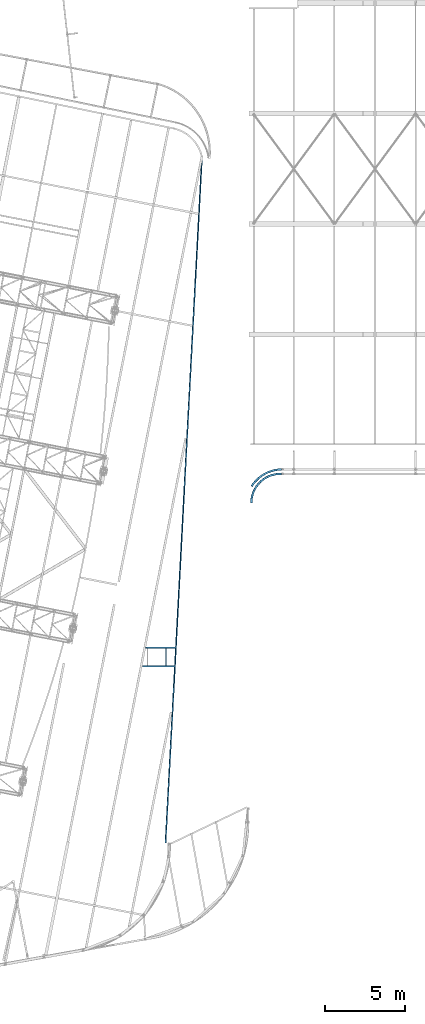
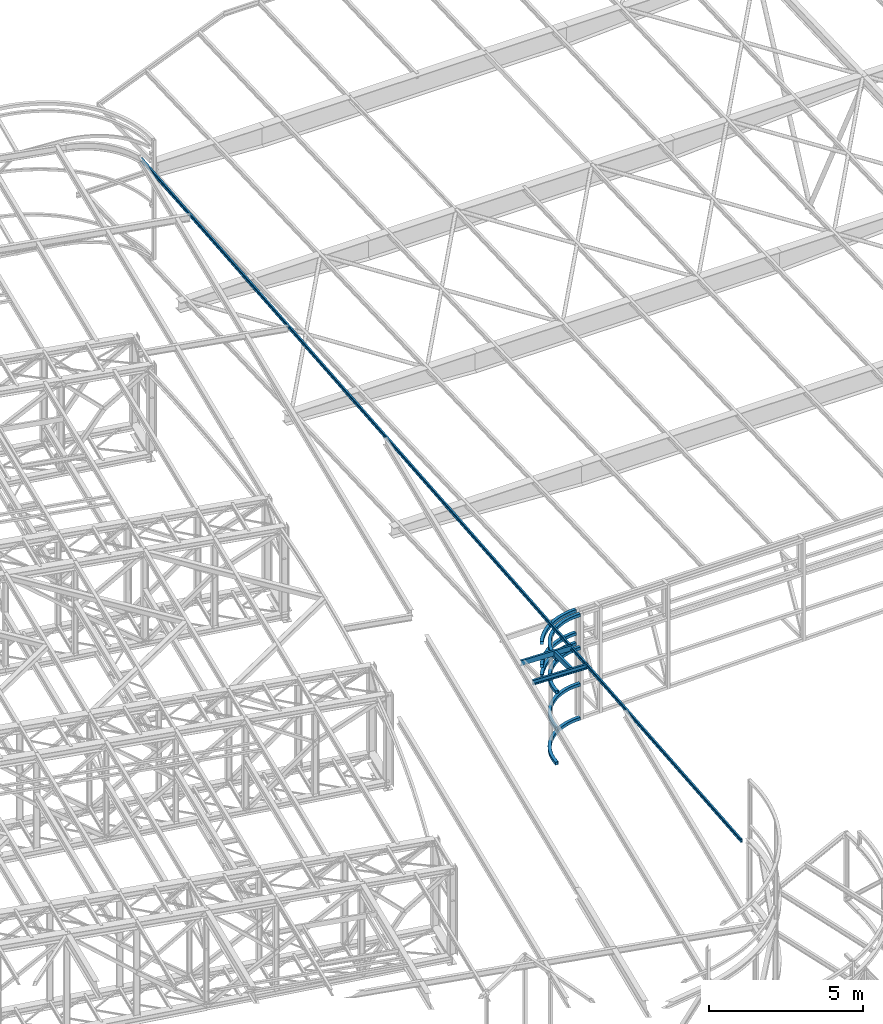
# One storey, part 104 of 215: 11 beams, 11 elements without a shape of their own.
"""IFC2X3 building model written with IfcOpenShell, lengths in millimetres."""

from ifc_helpers import new_model, entity, si_unit, frame, origin_with_axes, origin_2d_with_axis, place, context, subcontext, project, spatial, u_section, extrude, material, type_object, element, aggregate, save


model = new_model("IFC2X3")

# Units and contexts
model_context = context("Model", 3, precision=1e-05, world=origin_with_axes())
body_context = subcontext(model_context, "Body", "Model", "MODEL_VIEW")
ifc_project = project(units=[si_unit("LENGTHUNIT", "METRE", prefix="MILLI"), si_unit("AREAUNIT", "SQUARE_METRE"), si_unit("VOLUMEUNIT", "CUBIC_METRE"), si_unit("MASSUNIT", "GRAM", prefix="KILO"), si_unit("TIMEUNIT", "SECOND"), si_unit("PLANEANGLEUNIT", "RADIAN"), si_unit("SOLIDANGLEUNIT", "STERADIAN"), si_unit("THERMODYNAMICTEMPERATUREUNIT", "DEGREE_CELSIUS"), si_unit("LUMINOUSINTENSITYUNIT", "LUMEN")], contexts=[model_context])

# Site, building, storey
site_placement = place(None, origin_with_axes())
site = spatial("IfcSite", under=ifc_project, at=site_placement, CompositionType="ELEMENT")
building_placement = place(site_placement, origin_with_axes())
building = spatial("IfcBuilding", under=site, at=building_placement, Name="Undefined", CompositionType="ELEMENT")
storey_placement = place(building_placement, origin_with_axes())
storey = spatial("IfcBuildingStorey", under=building, at=storey_placement, Name="Undefined", CompositionType="ELEMENT", Elevation=0.0)

# Assembly, beam
assembly_1_placement = place(storey_placement, origin_with_axes())
assembly_1 = element("IfcElementAssembly", 1, at=assembly_1_placement, inside=storey, Name="Steel Assembly", AssemblyPlace="NOTDEFINED", PredefinedType="RIGID_FRAME")
ifc_material_1 = material(Name="STEEL/S275JR")
beam_type_1 = type_object("IfcBeamType", PredefinedType="NOTDEFINED")
beam_1_placement = place(assembly_1_placement, frame((104025.669995362, 32356.4568670024, 3370.16030146969), z_axis=(7.47739999995494e-05, -1.55810000009502e-05, -0.999999997083041), x_axis=(0.870179299035209, 0.492735207019937, 5.73900000024136e-05)))
beam_1 = element("IfcBeam", 2, at=beam_1_placement, type_object=beam_type_1, material=ifc_material_1, Name="LISSE", context=body_context, shape_type="SweptSolid", body=[
    entity("IfcRevolvedAreaSolid", entity("IfcRectangleHollowProfileDef", "AREA", None, entity("IfcAxis2Placement2D", entity("IfcCartesianPoint", [0.0, 0.0]), entity("IfcDirection", [1.0, 0.0])), 120.0, 120.0, 4.0, 4.0, 8.0), entity("IfcAxis2Placement3D", entity("IfcCartesianPoint", [2158.33336217342, 3.55848076031342e-12, 9.09480076337177e-13]), entity("IfcDirection", [-0.876297242918456, -0.481770839770853, 2.67341489622201e-21]), entity("IfcDirection", [0.481770839770854, -0.876297242918456, -9.20262728521858e-21])), entity("IfcAxis1Placement", entity("IfcCartesianPoint", [-2240.0, 0.0, 0.0]), entity("IfcDirection", [-6.93889390390723e-18, -1.0, -3.46944695195361e-18])), 1.00534882666948),
])
aggregate(assembly_1, [beam_1])

assembly_2_placement = place(storey_placement, origin_with_axes())
assembly_2 = element("IfcElementAssembly", 3, at=assembly_2_placement, inside=storey, Name="Steel Assembly", AssemblyPlace="NOTDEFINED", PredefinedType="RIGID_FRAME")
beam_2_placement = place(assembly_2_placement, frame((104025.669995238, 32356.4568648167, 2963.87464013908), z_axis=(7.47739999995494e-05, -1.55810000009502e-05, -0.999999997083041), x_axis=(0.870179299035209, 0.492735207019937, 5.73900000024136e-05)))
beam_2 = element("IfcBeam", 4, at=beam_2_placement, type_object=beam_type_1, material=ifc_material_1, Name="LISSE", context=body_context, shape_type="SweptSolid", body=[
    entity("IfcRevolvedAreaSolid", entity("IfcRectangleHollowProfileDef", "AREA", None, entity("IfcAxis2Placement2D", entity("IfcCartesianPoint", [0.0, 0.0]), entity("IfcDirection", [1.0, 0.0])), 120.0, 120.0, 4.0, 4.0, 8.0), entity("IfcAxis2Placement3D", entity("IfcCartesianPoint", [2158.33336217342, 3.55848076031342e-12, 9.09480076337177e-13]), entity("IfcDirection", [-0.876297242918456, -0.481770839770853, 2.67341489622201e-21]), entity("IfcDirection", [0.481770839770854, -0.876297242918456, -9.20262728521858e-21])), entity("IfcAxis1Placement", entity("IfcCartesianPoint", [-2240.0, 0.0, 0.0]), entity("IfcDirection", [-6.93889390390723e-18, -1.0, -3.46944695195361e-18])), 1.00534882669775),
])
aggregate(assembly_2, [beam_2])

assembly_3_placement = place(storey_placement, origin_with_axes())
assembly_3 = element("IfcElementAssembly", 5, at=assembly_3_placement, inside=storey, Name="Steel Assembly", AssemblyPlace="NOTDEFINED", PredefinedType="RIGID_FRAME")
beam_3_placement = place(assembly_3_placement, frame((104025.669995869, 32356.4580237206, 4279.06814958123), z_axis=(7.47739999995494e-05, -1.55810000009502e-05, -0.999999997083041), x_axis=(0.870179299035209, 0.492735207019937, 5.73900000024136e-05)))
beam_3 = element("IfcBeam", 6, at=beam_3_placement, type_object=beam_type_1, material=ifc_material_1, Name="LISSE", context=body_context, shape_type="SweptSolid", body=[
    entity("IfcRevolvedAreaSolid", entity("IfcRectangleHollowProfileDef", "AREA", None, entity("IfcAxis2Placement2D", entity("IfcCartesianPoint", [0.0, 0.0]), entity("IfcDirection", [1.0, 0.0])), 120.0, 120.0, 4.0, 4.0, 8.0), entity("IfcAxis2Placement3D", entity("IfcCartesianPoint", [2158.33336217342, 3.55848076031342e-12, 9.09480076337177e-13]), entity("IfcDirection", [-0.876297242918456, -0.481770839770853, 2.67341489622201e-21]), entity("IfcDirection", [0.481770839770854, -0.876297242918456, -9.20262728521858e-21])), entity("IfcAxis1Placement", entity("IfcCartesianPoint", [-2240.0, 0.0, 0.0]), entity("IfcDirection", [-6.93889390390723e-18, -1.0, -3.46944695195361e-18])), 1.0053488266773),
])
aggregate(assembly_3, [beam_3])

assembly_4_placement = place(storey_placement, origin_with_axes())
assembly_4 = element("IfcElementAssembly", 7, at=assembly_4_placement, inside=storey, Name="Steel Assembly", AssemblyPlace="NOTDEFINED", PredefinedType="RIGID_FRAME")
beam_4_placement = place(assembly_4_placement, frame((104014.079975564, 31329.9371526144, 1528.74815832066), z_axis=(7.11860000341247e-05, -1.69600000014436e-06, -0.999999997464838), x_axis=(0.722542649902781, 0.69132634590698, 5.02629999932533e-05)))
beam_4 = element("IfcBeam", 8, at=beam_4_placement, type_object=beam_type_1, material=ifc_material_1, Name="LISSE", context=body_context, shape_type="SweptSolid", body=[
    entity("IfcRevolvedAreaSolid", entity("IfcRectangleHollowProfileDef", "AREA", None, entity("IfcAxis2Placement2D", entity("IfcCartesianPoint", [0.0, 0.0]), entity("IfcDirection", [1.0, 0.0])), 120.0, 120.0, 4.0, 4.0, 8.0), entity("IfcAxis2Placement3D", entity("IfcCartesianPoint", [2618.09002087468, -1.77781559267515e-13, -2.27391416311285e-13]), entity("IfcDirection", [-0.690607991303626, -0.723229287534438, 4.67974177817026e-21]), entity("IfcDirection", [0.723229287534438, -0.690607991303626, -4.90079227968738e-21])), entity("IfcAxis1Placement", entity("IfcCartesianPoint", [-1810.0, 0.0, 0.0]), entity("IfcDirection", [-6.93889390390723e-18, -1.0, -3.46944695195361e-18])), 1.61693389840111),
])
aggregate(assembly_4, [beam_4])

assembly_5_placement = place(storey_placement, origin_with_axes())
assembly_5 = element("IfcElementAssembly", 9, at=assembly_5_placement, inside=storey, Name="Steel Assembly", AssemblyPlace="NOTDEFINED", PredefinedType="RIGID_FRAME")
beam_5_placement = place(assembly_5_placement, frame((104014.079024798, 31329.8937616743, 2963.86492069381), z_axis=(7.11860000341247e-05, -1.69600000014436e-06, -0.999999997464838), x_axis=(0.722553943342569, 0.691314542327757, 5.02620000237932e-05)))
beam_5 = element("IfcBeam", 10, at=beam_5_placement, type_object=beam_type_1, material=ifc_material_1, Name="LISSE", context=body_context, shape_type="SweptSolid", body=[
    entity("IfcRevolvedAreaSolid", entity("IfcRectangleHollowProfileDef", "AREA", None, entity("IfcAxis2Placement2D", entity("IfcCartesianPoint", [0.0, 0.0]), entity("IfcDirection", [1.0, 0.0])), 120.0, 120.0, 4.0, 4.0, 8.0), entity("IfcAxis2Placement3D", entity("IfcCartesianPoint", [2618.13544663623, 6.98052484652342e-12, -4.54800574414072e-13]), entity("IfcDirection", [-0.690594849773, -0.723241836087354, 1.89398354950742e-20]), entity("IfcDirection", [0.723241836087355, -0.690594849773, -1.00229792082735e-20])), entity("IfcAxis1Placement", entity("IfcCartesianPoint", [-1810.0, 0.0, 0.0]), entity("IfcDirection", [-6.93889390390723e-18, -1.0, -3.46944695195361e-18])), 1.61697023934262),
])
aggregate(assembly_5, [beam_5])

assembly_6_placement = place(storey_placement, origin_with_axes())
assembly_6 = element("IfcElementAssembly", 11, at=assembly_6_placement, inside=storey, Name="Steel Assembly", AssemblyPlace="NOTDEFINED", PredefinedType="RIGID_FRAME")
beam_6_placement = place(assembly_6_placement, frame((104012.75001456, 31329.92099728, 142.819788114607), z_axis=(0.0223282909900323, -0.000496082999780404, -0.999750569553787), x_axis=(0.722452822027949, 0.69123984802674, 0.0157921640006109)))
beam_6 = element("IfcBeam", 12, at=beam_6_placement, type_object=beam_type_1, material=ifc_material_1, Name="LISSE", context=body_context, shape_type="SweptSolid", body=[
    entity("IfcRevolvedAreaSolid", entity("IfcRectangleHollowProfileDef", "AREA", None, entity("IfcAxis2Placement2D", entity("IfcCartesianPoint", [0.0, 0.0]), entity("IfcDirection", [1.0, 0.0])), 120.0, 120.0, 4.0, 4.0, 8.0), entity("IfcAxis2Placement3D", entity("IfcCartesianPoint", [2618.41742379279, -7.04969777359323e-12, -9.08446034992012e-15]), entity("IfcDirection", [-0.690513263968231, -0.7233197303295, -1.13820294721474e-19]), entity("IfcDirection", [0.7233197303295, -0.690513263968231, -4.90521857263771e-18])), entity("IfcAxis1Placement", entity("IfcCartesianPoint", [-1810.0, 0.0, 0.0]), entity("IfcDirection", [-6.93889390390723e-18, -1.0, -3.46944695195361e-18])), 1.61719583860248),
])
aggregate(assembly_6, [beam_6])

assembly_7_placement = place(storey_placement, origin_with_axes())
assembly_7 = element("IfcElementAssembly", 13, at=assembly_7_placement, inside=storey, Name="Steel Assembly", AssemblyPlace="NOTDEFINED", PredefinedType="RIGID_FRAME")
beam_7_placement = place(assembly_7_placement, frame((104014.079024892, 31329.8948892622, 4279.05946919331), z_axis=(7.11860000341247e-05, -1.69600000014436e-06, -0.999999997464838), x_axis=(0.722542649902781, 0.69132634590698, 5.02629999932533e-05)))
beam_7 = element("IfcBeam", 14, at=beam_7_placement, type_object=beam_type_1, material=ifc_material_1, Name="LISSE", context=body_context, shape_type="SweptSolid", body=[
    entity("IfcRevolvedAreaSolid", entity("IfcRectangleHollowProfileDef", "AREA", None, entity("IfcAxis2Placement2D", entity("IfcCartesianPoint", [0.0, 0.0]), entity("IfcDirection", [1.0, 0.0])), 120.0, 120.0, 4.0, 4.0, 8.0), entity("IfcAxis2Placement3D", entity("IfcCartesianPoint", [2618.09087937142, 1.50284791278511e-11, 9.09530183520668e-13]), entity("IfcDirection", [-0.690607991303626, -0.723229287534438, 4.67974177817026e-21]), entity("IfcDirection", [0.723229287534438, -0.690607991303626, -4.90079227968738e-21])), entity("IfcAxis1Placement", entity("IfcCartesianPoint", [-1810.0, 0.0, 0.0]), entity("IfcDirection", [-6.93889390390723e-18, -1.0, -3.46944695195361e-18])), 1.61693458519838),
])
aggregate(assembly_7, [beam_7])

assembly_8_placement = place(storey_placement, origin_with_axes())
assembly_8 = element("IfcElementAssembly", 15, at=assembly_8_placement, inside=storey, Name="Steel Assembly", AssemblyPlace="NOTDEFINED", PredefinedType="RIGID_FRAME")
beam_type_2 = type_object("IfcBeamType", Name="UPN140", PredefinedType="NOTDEFINED")
beam_8_placement = place(assembly_8_placement, frame((100921.161895369, 52954.1779891363, 12034.4892699105), z_axis=(-0.000229469999991258, -0.00432196499973126, 0.999990633937169), x_axis=(-0.0530187159748533, -0.998584139526372, -0.00432805299794719)))
beam_8 = element("IfcBeam", 16, at=beam_8_placement, type_object=beam_type_2, material=ifc_material_1, ObjectType="UPN140", context=body_context, shape_type="SweptSolid", body=[
    extrude(u_section(Depth=140.0, FlangeWidth=60.0, WebThickness=7.0, FlangeThickness=10.0, FilletRadius=10.0, EdgeRadius=5.0, FlangeSlope=0.0798299857122373, at=origin_2d_with_axis()), frame((42954.2499701027, -1.45646444857376e-11, 7.45137458161132e-14), z_axis=(-1.0, 0.0, 0.0), x_axis=(-6.93889390390723e-18, -1.0, -3.46944695195361e-18)), (0.0, 0.0, 1.0), 42954.2),
])
aggregate(assembly_8, [beam_8])

assembly_9_placement = place(storey_placement, origin_with_axes())
assembly_9 = element("IfcElementAssembly", 17, at=assembly_9_placement, inside=storey, Name="Steel Assembly", AssemblyPlace="NOTDEFINED", PredefinedType="RIGID_FRAME")
ifc_material_2 = material(Name="STEEL/S235JR")
beam_type_3 = type_object("IfcBeamType", Name="UPN200", PredefinedType="NOTDEFINED")
beam_9_placement = place(assembly_9_placement, frame((99319.0367523965, 22264.6549551396, 11870.9751015954), z_axis=(0.0303815210100789, -0.0060801320020156, 0.999519882331488), x_axis=(-0.999538374782733, -0.000162678999964419, 0.0303810939933964)))
beam_9 = element("IfcBeam", 18, at=beam_9_placement, type_object=beam_type_3, material=ifc_material_2, ObjectType="UPN200", context=body_context, shape_type="SweptSolid", body=[
    extrude(u_section(Depth=200.0, FlangeWidth=75.0, WebThickness=8.5, FlangeThickness=11.5, FilletRadius=11.5, EdgeRadius=6.0, FlangeSlope=0.0798299857122373, at=origin_2d_with_axis()), frame((1913.97369417925, 5.18783609327316e-17, 1.81898940354586e-12), z_axis=(-1.0, 0.0, 0.0), x_axis=(-6.93889390390723e-18, -1.0, -3.46944695195361e-18)), (0.0, 0.0, 1.0), 1914.0),
])
aggregate(assembly_9, [beam_9])

assembly_10_placement = place(storey_placement, origin_with_axes())
assembly_10 = element("IfcElementAssembly", 19, at=assembly_10_placement, inside=storey, Name="Steel Assembly", AssemblyPlace="NOTDEFINED", PredefinedType="RIGID_FRAME")
beam_10_placement = place(assembly_10_placement, frame((98672.760638065, 21147.1204597943, 11883.8213631909), z_axis=(0.0303815210100789, -0.0060801320020156, 0.999519882331488), x_axis=(1.83579999957495e-05, 0.999981501975007, 0.00608238199984827)))
beam_10 = element("IfcBeam", 20, at=beam_10_placement, type_object=beam_type_3, material=ifc_material_2, ObjectType="UPN200", context=body_context, shape_type="SweptSolid", body=[
    extrude(u_section(Depth=200.0, FlangeWidth=75.0, WebThickness=8.5, FlangeThickness=11.5, FilletRadius=11.5, EdgeRadius=6.0, FlangeSlope=0.0798299857122373, at=origin_2d_with_axis()), frame((1079.96358222926, -1.45519152283669e-11, -1.81898940354586e-12), z_axis=(-1.0, 0.0, 0.0), x_axis=(-6.93889390390723e-18, -1.0, -3.46944695195361e-18)), (0.0, 0.0, 1.0), 1080.0),
])
aggregate(assembly_10, [beam_10])

assembly_11_placement = place(storey_placement, origin_with_axes())
assembly_11 = element("IfcElementAssembly", 21, at=assembly_11_placement, inside=storey, Name="Steel Assembly", AssemblyPlace="NOTDEFINED", PredefinedType="RIGID_FRAME")
beam_11_placement = place(assembly_11_placement, frame((97194.8047187408, 21109.3198910331, 11928.5155382146), z_axis=(0.0303815210100789, -0.0060801320020156, 0.999519882331488), x_axis=(0.999538374786745, 0.000162840999964475, -0.0303810929935184)))
beam_11 = element("IfcBeam", 22, at=beam_11_placement, type_object=beam_type_3, material=ifc_material_2, ObjectType="UPN200", context=body_context, shape_type="SweptSolid", body=[
    extrude(u_section(Depth=200.0, FlangeWidth=75.0, WebThickness=8.5, FlangeThickness=11.5, FilletRadius=11.5, EdgeRadius=6.0, FlangeSlope=0.0798299857122373, at=origin_2d_with_axis()), frame((2062.72070732325, 5.59101568027673e-17, 3.63797880709171e-12), z_axis=(-1.0, 0.0, 0.0), x_axis=(-6.93889390390723e-18, -1.0, -3.46944695195361e-18)), (0.0, 0.0, 1.0), 2062.7),
])
aggregate(assembly_11, [beam_11])

save(model, "model.ifc")
